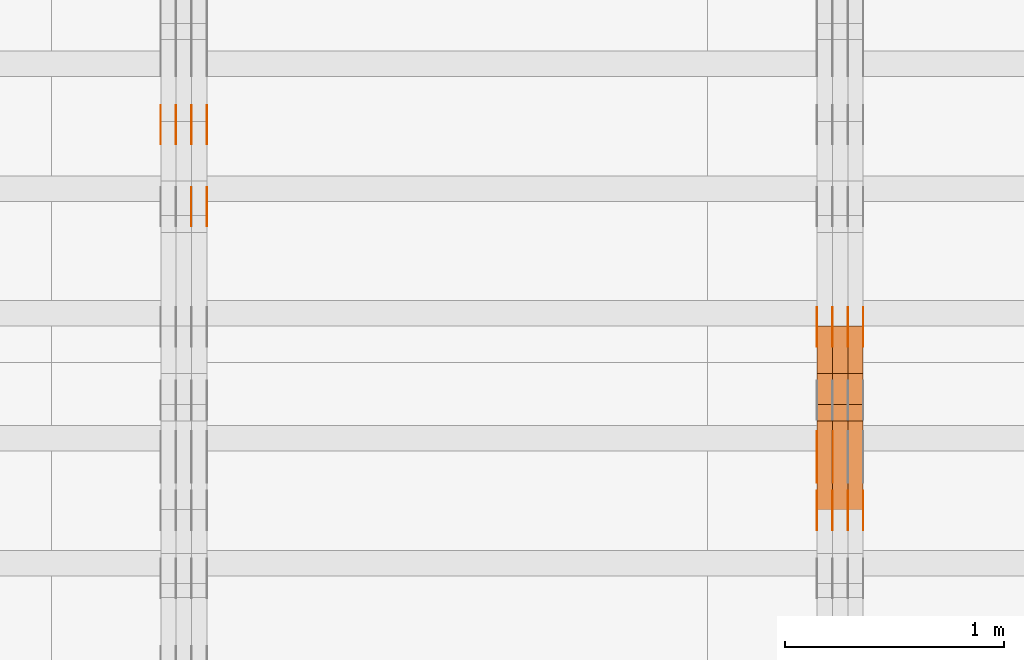
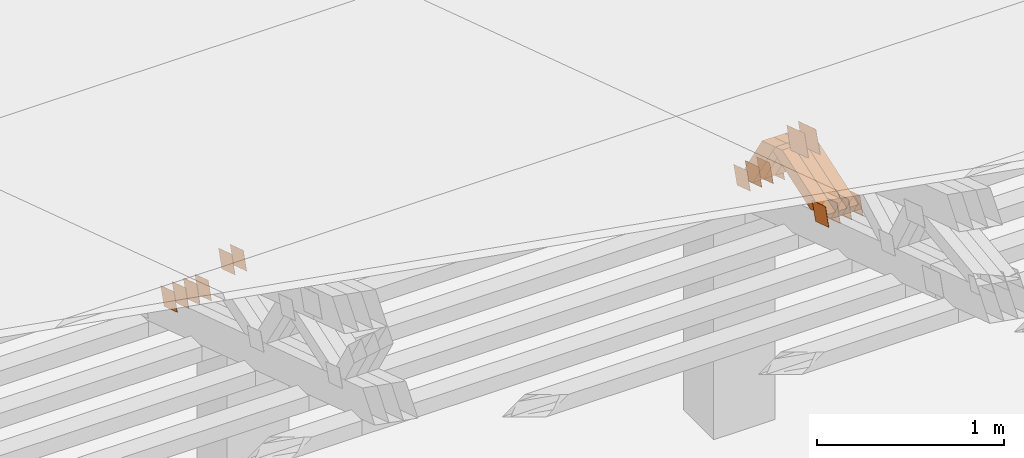
# One storey, part 338 of 385: 28 proxies.
"""IFC2X3 building model written with IfcOpenShell, lengths in millimetres."""

from ifc_helpers import new_model, entity, si_unit, converted_unit, derived_unit, direction, frame, origin, place, context, subcontext, project, spatial, polyline, outline, extrude, source, transform, mapped, material, type_object, type_shapes, element, save


model = new_model("IFC2X3")

# Units and contexts
model_context = context("Model", 3, precision=0.01, world=origin(), true_north=direction((6.12303176911189e-17, 1.0)))
body_context = subcontext(model_context, "Body", "Model", "MODEL_VIEW")
ifc_project = project(units=[si_unit("LENGTHUNIT", "METRE", prefix="MILLI"), si_unit("AREAUNIT", "SQUARE_METRE"), si_unit("VOLUMEUNIT", "CUBIC_METRE"), converted_unit("PLANEANGLEUNIT", "DEGREE", entity("IfcRatioMeasure", 0.0174532925199433), si_unit("PLANEANGLEUNIT", "RADIAN"), dimensions=[0, 0, 0, 0, 0, 0, 0]), si_unit("MASSUNIT", "GRAM", prefix="KILO"), derived_unit("MASSDENSITYUNIT", [(si_unit("MASSUNIT", "GRAM", prefix="KILO"), 1), (si_unit("LENGTHUNIT", "METRE"), -3)]), si_unit("TIMEUNIT", "SECOND"), si_unit("FREQUENCYUNIT", "HERTZ"), si_unit("THERMODYNAMICTEMPERATUREUNIT", "DEGREE_CELSIUS"), derived_unit("THERMALTRANSMITTANCEUNIT", [(si_unit("MASSUNIT", "GRAM", prefix="KILO"), 1), (si_unit("THERMODYNAMICTEMPERATUREUNIT", "KELVIN"), -1), (si_unit("TIMEUNIT", "SECOND"), -3)]), derived_unit("VOLUMETRICFLOWRATEUNIT", [(si_unit("LENGTHUNIT", "METRE"), 3), (si_unit("TIMEUNIT", "SECOND"), -1)]), si_unit("ELECTRICCURRENTUNIT", "AMPERE"), si_unit("ELECTRICVOLTAGEUNIT", "VOLT"), si_unit("POWERUNIT", "WATT"), si_unit("FORCEUNIT", "NEWTON", prefix="KILO"), si_unit("ILLUMINANCEUNIT", "LUX"), si_unit("LUMINOUSFLUXUNIT", "LUMEN"), si_unit("LUMINOUSINTENSITYUNIT", "CANDELA"), derived_unit("USERDEFINED", [(si_unit("MASSUNIT", "GRAM", prefix="KILO"), -1), (si_unit("LENGTHUNIT", "METRE"), -2), (si_unit("TIMEUNIT", "SECOND"), 3), (si_unit("LUMINOUSFLUXUNIT", "LUMEN"), 1)]), derived_unit("LINEARVELOCITYUNIT", [(si_unit("LENGTHUNIT", "METRE"), 1), (si_unit("TIMEUNIT", "SECOND"), -1)]), si_unit("PRESSUREUNIT", "PASCAL"), derived_unit("USERDEFINED", [(si_unit("LENGTHUNIT", "METRE"), -2), (si_unit("MASSUNIT", "GRAM", prefix="KILO"), 1), (si_unit("TIMEUNIT", "SECOND"), -2)])], contexts=[model_context])

# Site, building, storey
site_placement = place(None, origin())
site = spatial("IfcSite", under=ifc_project, at=site_placement, CompositionType="ELEMENT")
building_placement = place(site_placement, origin())
building = spatial("IfcBuilding", under=site, at=building_placement, CompositionType="ELEMENT")
storey_placement = place(building_placement, origin())
storey = spatial("IfcBuildingStorey", under=building, at=storey_placement, Name="Default", CompositionType="ELEMENT", Elevation=0.0)

# Proxies
ifc_material_1 = material(Name="IfcSurfaceStyle #485736")
building_element_proxy_type_1 = type_object("IfcBuildingElementProxyType", PredefinedType="NOTDEFINED", material=ifc_material_1)
shared_shape_1 = source(origin(), body_context, "Body", "SweptSolid", [
    extrude(outline(polyline([(-100.000260677523, -72.0000050220369), (100.000341220114, -72.0000050220369), (99.9997962944585, 72.0000050220369), (-99.9998768370492, 72.0000050220369), (-100.000260677523, -72.0000050220369)])), frame((100.000341220114, 72.0001826453454, 0.0), z_axis=(0.0, 0.0, 1.0), x_axis=(-1.0, 0.0, 0.0)), (0.0, 0.0, 1.0), 1.29999999999998),
])
type_shapes(building_element_proxy_type_1, [shared_shape_1])
proxy_1_placement = place(building_placement, frame((39246.3, 20382.8706354426, 2409.35285895246), z_axis=(-1.0, 0.0, 0.0), x_axis=(0.0, -0.951056516295154, 0.309016994374948)))
element("IfcBuildingElementProxy", 1, at=proxy_1_placement, inside=storey, type_object=building_element_proxy_type_1, material=ifc_material_1, context=body_context, shape_type="MappedRepresentation", body=[
    mapped(shared_shape_1, transform((0.0, 0.0, 0.0), scale=1.0)),
])
ifc_material_2 = material(Name="IfcSurfaceStyle #485679")
building_element_proxy_type_2 = type_object("IfcBuildingElementProxyType", PredefinedType="NOTDEFINED", material=ifc_material_2)
shared_shape_2 = source(origin(), body_context, "Body", "SweptSolid", [
    extrude(outline(polyline([(-100.000260677523, -72.0000050220369), (100.000341220114, -72.0000050220369), (99.9997962944585, 72.0000050220369), (-99.9998768370492, 72.0000050220369), (-100.000260677523, -72.0000050220369)])), frame((100.000341220114, 72.0001826453454, 0.0), z_axis=(0.0, 0.0, 1.0), x_axis=(-1.0, 0.0, 0.0)), (0.0, 0.0, 1.0), 1.29999999999999),
])
type_shapes(building_element_proxy_type_2, [shared_shape_2])
proxy_2_placement = place(building_placement, frame((39175.0, 20382.8706354426, 2409.35285895246), z_axis=(-1.0, 0.0, 0.0), x_axis=(0.0, -0.951056516295154, 0.309016994374948)))
element("IfcBuildingElementProxy", 2, at=proxy_2_placement, inside=storey, type_object=building_element_proxy_type_2, material=ifc_material_2, context=body_context, shape_type="MappedRepresentation", body=[
    mapped(shared_shape_2, transform((0.0, 0.0, 0.0), scale=1.0)),
])
ifc_material_3 = material(Name="IfcSurfaceStyle #479466")
building_element_proxy_type_3 = type_object("IfcBuildingElementProxyType", PredefinedType="NOTDEFINED", material=ifc_material_3)
shared_shape_3 = source(origin(), body_context, "Body", "SweptSolid", [
    extrude(outline(polyline([(-74.9998605591118, -59.9999264677598), (74.9998754286171, -59.9999264677598), (74.9998605591136, 59.9999264677598), (-74.9998754286189, 59.9999264677598), (-74.9998605591118, -59.9999264677598)])), frame((75.0000347664736, 60.0000016373434, 0.0), z_axis=(0.0, 0.0, 1.0), x_axis=(-1.0, 0.0, 0.0)), (0.0, 0.0, 1.0), 1.3),
])
type_shapes(building_element_proxy_type_3, [shared_shape_3])
proxy_3_placement = place(building_placement, frame((39386.3, 20117.0890328685, 2105.40814929196), z_axis=(-1.0, 0.0, 0.0), x_axis=(0.0, -0.951056516295124, 0.309016994375039)))
element("IfcBuildingElementProxy", 3, at=proxy_3_placement, inside=storey, type_object=building_element_proxy_type_3, material=ifc_material_3, context=body_context, shape_type="MappedRepresentation", body=[
    mapped(shared_shape_3, transform((0.0, 0.0, 0.0), scale=1.0)),
])
ifc_material_4 = material(Name="IfcSurfaceStyle #479409")
building_element_proxy_type_4 = type_object("IfcBuildingElementProxyType", PredefinedType="NOTDEFINED", material=ifc_material_4)
shared_shape_4 = source(origin(), body_context, "Body", "SweptSolid", [
    extrude(outline(polyline([(-74.9998605591118, -59.9999264677598), (74.9998754286171, -59.9999264677598), (74.9998605591136, 59.9999264677598), (-74.9998754286189, 59.9999264677598), (-74.9998605591118, -59.9999264677598)])), frame((75.0000347664736, 60.0000016373434, 0.0), z_axis=(0.0, 0.0, 1.0), x_axis=(-1.0, 0.0, 0.0)), (0.0, 0.0, 1.0), 1.3),
])
type_shapes(building_element_proxy_type_4, [shared_shape_4])
proxy_4_placement = place(building_placement, frame((39315.0, 20117.0890328685, 2105.40814929196), z_axis=(-1.0, 0.0, 0.0), x_axis=(0.0, -0.951056516295124, 0.309016994375039)))
element("IfcBuildingElementProxy", 4, at=proxy_4_placement, inside=storey, type_object=building_element_proxy_type_4, material=ifc_material_4, context=body_context, shape_type="MappedRepresentation", body=[
    mapped(shared_shape_4, transform((0.0, 0.0, 0.0), scale=1.0)),
])
ifc_material_5 = material(Name="IfcSurfaceStyle #479352")
building_element_proxy_type_5 = type_object("IfcBuildingElementProxyType", PredefinedType="NOTDEFINED", material=ifc_material_5)
shared_shape_5 = source(origin(), body_context, "Body", "SweptSolid", [
    extrude(outline(polyline([(-74.9998605591118, -59.9999264677598), (74.9998754286171, -59.9999264677598), (74.9998605591136, 59.9999264677598), (-74.9998754286189, 59.9999264677598), (-74.9998605591118, -59.9999264677598)])), frame((75.0000347664736, 60.0000016373434, 0.0), z_axis=(0.0, 0.0, 1.0), x_axis=(-1.0, 0.0, 0.0)), (0.0, 0.0, 1.0), 1.3),
])
type_shapes(building_element_proxy_type_5, [shared_shape_5])
proxy_5_placement = place(building_placement, frame((39316.3, 20117.0890328685, 2105.40814929196), z_axis=(-1.0, 0.0, 0.0), x_axis=(0.0, -0.951056516295124, 0.309016994375039)))
element("IfcBuildingElementProxy", 5, at=proxy_5_placement, inside=storey, type_object=building_element_proxy_type_5, material=ifc_material_5, context=body_context, shape_type="MappedRepresentation", body=[
    mapped(shared_shape_5, transform((0.0, 0.0, 0.0), scale=1.0)),
])
ifc_material_6 = material(Name="IfcSurfaceStyle #479295")
building_element_proxy_type_6 = type_object("IfcBuildingElementProxyType", PredefinedType="NOTDEFINED", material=ifc_material_6)
shared_shape_6 = source(origin(), body_context, "Body", "SweptSolid", [
    extrude(outline(polyline([(-74.9998605591118, -59.9999264677598), (74.9998754286171, -59.9999264677598), (74.9998605591136, 59.9999264677598), (-74.9998754286189, 59.9999264677598), (-74.9998605591118, -59.9999264677598)])), frame((75.0000347664736, 60.0000016373434, 0.0), z_axis=(0.0, 0.0, 1.0), x_axis=(-1.0, 0.0, 0.0)), (0.0, 0.0, 1.0), 1.29999999999999),
])
type_shapes(building_element_proxy_type_6, [shared_shape_6])
proxy_6_placement = place(building_placement, frame((39245.0, 20117.0890328685, 2105.40814929196), z_axis=(-1.0, 0.0, 0.0), x_axis=(0.0, -0.951056516295124, 0.309016994375039)))
element("IfcBuildingElementProxy", 6, at=proxy_6_placement, inside=storey, type_object=building_element_proxy_type_6, material=ifc_material_6, context=body_context, shape_type="MappedRepresentation", body=[
    mapped(shared_shape_6, transform((0.0, 0.0, 0.0), scale=1.0)),
])
ifc_material_7 = material(Name="IfcSurfaceStyle #479238")
building_element_proxy_type_7 = type_object("IfcBuildingElementProxyType", PredefinedType="NOTDEFINED", material=ifc_material_7)
shared_shape_7 = source(origin(), body_context, "Body", "SweptSolid", [
    extrude(outline(polyline([(-74.9998605591118, -59.9999264677598), (74.9998754286171, -59.9999264677598), (74.9998605591136, 59.9999264677598), (-74.9998754286189, 59.9999264677598), (-74.9998605591118, -59.9999264677598)])), frame((75.0000347664736, 60.0000016373434, 0.0), z_axis=(0.0, 0.0, 1.0), x_axis=(-1.0, 0.0, 0.0)), (0.0, 0.0, 1.0), 1.29999999999999),
])
type_shapes(building_element_proxy_type_7, [shared_shape_7])
proxy_7_placement = place(building_placement, frame((39246.3, 20117.0890328685, 2105.40814929196), z_axis=(-1.0, 0.0, 0.0), x_axis=(0.0, -0.951056516295124, 0.309016994375039)))
element("IfcBuildingElementProxy", 7, at=proxy_7_placement, inside=storey, type_object=building_element_proxy_type_7, material=ifc_material_7, context=body_context, shape_type="MappedRepresentation", body=[
    mapped(shared_shape_7, transform((0.0, 0.0, 0.0), scale=1.0)),
])
ifc_material_8 = material(Name="IfcSurfaceStyle #479181")
building_element_proxy_type_8 = type_object("IfcBuildingElementProxyType", PredefinedType="NOTDEFINED", material=ifc_material_8)
shared_shape_8 = source(origin(), body_context, "Body", "SweptSolid", [
    extrude(outline(polyline([(-74.9998605591118, -59.9999264677598), (74.9998754286171, -59.9999264677598), (74.9998605591136, 59.9999264677598), (-74.9998754286189, 59.9999264677598), (-74.9998605591118, -59.9999264677598)])), frame((75.0000347664736, 60.0000016373434, 0.0), z_axis=(0.0, 0.0, 1.0), x_axis=(-1.0, 0.0, 0.0)), (0.0, 0.0, 1.0), 1.29999999999999),
])
type_shapes(building_element_proxy_type_8, [shared_shape_8])
proxy_8_placement = place(building_placement, frame((39175.0, 20117.0890328685, 2105.40814929196), z_axis=(-1.0, 0.0, 0.0), x_axis=(0.0, -0.951056516295124, 0.309016994375039)))
element("IfcBuildingElementProxy", 8, at=proxy_8_placement, inside=storey, type_object=building_element_proxy_type_8, material=ifc_material_8, context=body_context, shape_type="MappedRepresentation", body=[
    mapped(shared_shape_8, transform((0.0, 0.0, 0.0), scale=1.0)),
])
ifc_material_9 = material(Name="IfcSurfaceStyle #479124")
building_element_proxy_type_9 = type_object("IfcBuildingElementProxyType", PredefinedType="NOTDEFINED", material=ifc_material_9)
shared_shape_9 = source(origin(), body_context, "Body", "SweptSolid", [
    extrude(outline(polyline([(-74.9998794200132, -59.999984515643), (74.9998565677174, -59.999984515643), (74.9998794200123, 59.999984515643), (-74.9998565677165, 59.999984515643), (-74.9998794200132, -59.999984515643)])), frame((75.0002235343086, 60.0000596852268, 0.0), z_axis=(0.0, 0.0, 1.0), x_axis=(-1.0, 0.0, 0.0)), (0.0, 0.0, 1.0), 1.3),
])
type_shapes(building_element_proxy_type_9, [shared_shape_9])
proxy_9_placement = place(building_placement, frame((39386.3, 20956.2317725846, 1832.75404405346), z_axis=(-1.0, 0.0, 0.0), x_axis=(0.0, -0.951056516295124, 0.309016994375039)))
element("IfcBuildingElementProxy", 9, at=proxy_9_placement, inside=storey, type_object=building_element_proxy_type_9, material=ifc_material_9, context=body_context, shape_type="MappedRepresentation", body=[
    mapped(shared_shape_9, transform((0.0, 0.0, 0.0), scale=1.0)),
])
ifc_material_10 = material(Name="IfcSurfaceStyle #479067")
building_element_proxy_type_10 = type_object("IfcBuildingElementProxyType", PredefinedType="NOTDEFINED", material=ifc_material_10)
shared_shape_10 = source(origin(), body_context, "Body", "SweptSolid", [
    extrude(outline(polyline([(-74.9998794200132, -59.999984515643), (74.9998565677174, -59.999984515643), (74.9998794200123, 59.999984515643), (-74.9998565677165, 59.999984515643), (-74.9998794200132, -59.999984515643)])), frame((75.0002235343086, 60.0000596852268, 0.0), z_axis=(0.0, 0.0, 1.0), x_axis=(-1.0, 0.0, 0.0)), (0.0, 0.0, 1.0), 1.3),
])
type_shapes(building_element_proxy_type_10, [shared_shape_10])
proxy_10_placement = place(building_placement, frame((39315.0, 20956.2317725846, 1832.75404405346), z_axis=(-1.0, 0.0, 0.0), x_axis=(0.0, -0.951056516295124, 0.309016994375039)))
element("IfcBuildingElementProxy", 10, at=proxy_10_placement, inside=storey, type_object=building_element_proxy_type_10, material=ifc_material_10, context=body_context, shape_type="MappedRepresentation", body=[
    mapped(shared_shape_10, transform((0.0, 0.0, 0.0), scale=1.0)),
])
ifc_material_11 = material(Name="IfcSurfaceStyle #479010")
building_element_proxy_type_11 = type_object("IfcBuildingElementProxyType", PredefinedType="NOTDEFINED", material=ifc_material_11)
shared_shape_11 = source(origin(), body_context, "Body", "SweptSolid", [
    extrude(outline(polyline([(-74.9998794200132, -59.999984515643), (74.9998565677174, -59.999984515643), (74.9998794200123, 59.999984515643), (-74.9998565677165, 59.999984515643), (-74.9998794200132, -59.999984515643)])), frame((75.0002235343086, 60.0000596852268, 0.0), z_axis=(0.0, 0.0, 1.0), x_axis=(-1.0, 0.0, 0.0)), (0.0, 0.0, 1.0), 1.3),
])
type_shapes(building_element_proxy_type_11, [shared_shape_11])
proxy_11_placement = place(building_placement, frame((39316.3, 20956.2317725846, 1832.75404405346), z_axis=(-1.0, 0.0, 0.0), x_axis=(0.0, -0.951056516295124, 0.309016994375039)))
element("IfcBuildingElementProxy", 11, at=proxy_11_placement, inside=storey, type_object=building_element_proxy_type_11, material=ifc_material_11, context=body_context, shape_type="MappedRepresentation", body=[
    mapped(shared_shape_11, transform((0.0, 0.0, 0.0), scale=1.0)),
])
ifc_material_12 = material(Name="IfcSurfaceStyle #478953")
building_element_proxy_type_12 = type_object("IfcBuildingElementProxyType", PredefinedType="NOTDEFINED", material=ifc_material_12)
shared_shape_12 = source(origin(), body_context, "Body", "SweptSolid", [
    extrude(outline(polyline([(-74.9998794200132, -59.999984515643), (74.9998565677174, -59.999984515643), (74.9998794200123, 59.999984515643), (-74.9998565677165, 59.999984515643), (-74.9998794200132, -59.999984515643)])), frame((75.0002235343086, 60.0000596852268, 0.0), z_axis=(0.0, 0.0, 1.0), x_axis=(-1.0, 0.0, 0.0)), (0.0, 0.0, 1.0), 1.29999999999999),
])
type_shapes(building_element_proxy_type_12, [shared_shape_12])
proxy_12_placement = place(building_placement, frame((39245.0, 20956.2317725846, 1832.75404405346), z_axis=(-1.0, 0.0, 0.0), x_axis=(0.0, -0.951056516295124, 0.309016994375039)))
element("IfcBuildingElementProxy", 12, at=proxy_12_placement, inside=storey, type_object=building_element_proxy_type_12, material=ifc_material_12, context=body_context, shape_type="MappedRepresentation", body=[
    mapped(shared_shape_12, transform((0.0, 0.0, 0.0), scale=1.0)),
])
ifc_material_13 = material(Name="IfcSurfaceStyle #478896")
building_element_proxy_type_13 = type_object("IfcBuildingElementProxyType", PredefinedType="NOTDEFINED", material=ifc_material_13)
shared_shape_13 = source(origin(), body_context, "Body", "SweptSolid", [
    extrude(outline(polyline([(-74.9998794200132, -59.999984515643), (74.9998565677174, -59.999984515643), (74.9998794200123, 59.999984515643), (-74.9998565677165, 59.999984515643), (-74.9998794200132, -59.999984515643)])), frame((75.0002235343086, 60.0000596852268, 0.0), z_axis=(0.0, 0.0, 1.0), x_axis=(-1.0, 0.0, 0.0)), (0.0, 0.0, 1.0), 1.29999999999999),
])
type_shapes(building_element_proxy_type_13, [shared_shape_13])
proxy_13_placement = place(building_placement, frame((39246.3, 20956.2317725846, 1832.75404405346), z_axis=(-1.0, 0.0, 0.0), x_axis=(0.0, -0.951056516295124, 0.309016994375039)))
element("IfcBuildingElementProxy", 13, at=proxy_13_placement, inside=storey, type_object=building_element_proxy_type_13, material=ifc_material_13, context=body_context, shape_type="MappedRepresentation", body=[
    mapped(shared_shape_13, transform((0.0, 0.0, 0.0), scale=1.0)),
])
ifc_material_14 = material(Name="IfcSurfaceStyle #478839")
building_element_proxy_type_14 = type_object("IfcBuildingElementProxyType", PredefinedType="NOTDEFINED", material=ifc_material_14)
shared_shape_14 = source(origin(), body_context, "Body", "SweptSolid", [
    extrude(outline(polyline([(-74.9998794200132, -59.999984515643), (74.9998565677174, -59.999984515643), (74.9998794200123, 59.999984515643), (-74.9998565677165, 59.999984515643), (-74.9998794200132, -59.999984515643)])), frame((75.0002235343086, 60.0000596852268, 0.0), z_axis=(0.0, 0.0, 1.0), x_axis=(-1.0, 0.0, 0.0)), (0.0, 0.0, 1.0), 1.29999999999999),
])
type_shapes(building_element_proxy_type_14, [shared_shape_14])
proxy_14_placement = place(building_placement, frame((39175.0, 20956.2317725846, 1832.75404405346), z_axis=(-1.0, 0.0, 0.0), x_axis=(0.0, -0.951056516295124, 0.309016994375039)))
element("IfcBuildingElementProxy", 14, at=proxy_14_placement, inside=storey, type_object=building_element_proxy_type_14, material=ifc_material_14, context=body_context, shape_type="MappedRepresentation", body=[
    mapped(shared_shape_14, transform((0.0, 0.0, 0.0), scale=1.0)),
])
ifc_material_15 = material(Name="IfcSurfaceStyle #461862")
building_element_proxy_type_15 = type_object("IfcBuildingElementProxyType", Name="T1-W26 461860", PredefinedType="NOTDEFINED", material=ifc_material_15)
shared_shape_15 = source(origin(), body_context, "Body", "SweptSolid", [
    extrude(outline(polyline([(-339.390941716546, -47.5001331548025), (137.738864791781, -47.5001331548025), (201.272298560955, 6.02772073885038e-05), (212.703852542003, 47.5001030161988), (-212.324074178193, 47.5001030161988), (-339.390941716546, -47.5001331548025)])), frame((212.703852542003, 47.5001030161988, 0.0), z_axis=(0.0, 0.0, 1.0), x_axis=(-1.0, 0.0, 0.0)), (0.0, 0.0, 1.0), 70.0),
])
type_shapes(building_element_proxy_type_15, [shared_shape_15])
proxy_15_placement = place(building_placement, frame((39385.0, 20576.541015625, 2286.80981445313), z_axis=(-1.0, 0.0, 0.0), x_axis=(0.0, -0.946743816465327, -0.321987804093053)))
element("IfcBuildingElementProxy", 15, at=proxy_15_placement, inside=storey, type_object=building_element_proxy_type_15, material=ifc_material_15, Name="T1-W26", context=body_context, shape_type="MappedRepresentation", body=[
    mapped(shared_shape_15, transform((0.0, 0.0, 0.0), scale=1.0)),
])
ifc_material_16 = material(Name="IfcSurfaceStyle #461796")
building_element_proxy_type_16 = type_object("IfcBuildingElementProxyType", Name="T1-W26 461794", PredefinedType="NOTDEFINED", material=ifc_material_16)
shared_shape_16 = source(origin(), body_context, "Body", "SweptSolid", [
    extrude(outline(polyline([(-339.390941716546, -47.5001331548025), (137.738864791781, -47.5001331548025), (201.272298560955, 6.02772073885038e-05), (212.703852542003, 47.5001030161988), (-212.324074178193, 47.5001030161988), (-339.390941716546, -47.5001331548025)])), frame((212.703852542003, 47.5001030161988, 0.0), z_axis=(0.0, 0.0, 1.0), x_axis=(-1.0, 0.0, 0.0)), (0.0, 0.0, 1.0), 70.0),
])
type_shapes(building_element_proxy_type_16, [shared_shape_16])
proxy_16_placement = place(building_placement, frame((39315.0, 20576.541015625, 2286.80981445313), z_axis=(-1.0, 0.0, 0.0), x_axis=(0.0, -0.946743816465327, -0.321987804093053)))
element("IfcBuildingElementProxy", 16, at=proxy_16_placement, inside=storey, type_object=building_element_proxy_type_16, material=ifc_material_16, Name="T1-W26", context=body_context, shape_type="MappedRepresentation", body=[
    mapped(shared_shape_16, transform((0.0, 0.0, 0.0), scale=1.0)),
])
ifc_material_17 = material(Name="IfcSurfaceStyle #461730")
building_element_proxy_type_17 = type_object("IfcBuildingElementProxyType", Name="T1-W26 461728", PredefinedType="NOTDEFINED", material=ifc_material_17)
shared_shape_17 = source(origin(), body_context, "Body", "SweptSolid", [
    extrude(outline(polyline([(-339.390941716546, -47.5001331548025), (137.738864791781, -47.5001331548025), (201.272298560955, 6.02772073885038e-05), (212.703852542003, 47.5001030161988), (-212.324074178193, 47.5001030161988), (-339.390941716546, -47.5001331548025)])), frame((212.703852542003, 47.5001030161988, 0.0), z_axis=(0.0, 0.0, 1.0), x_axis=(-1.0, 0.0, 0.0)), (0.0, 0.0, 1.0), 70.0),
])
type_shapes(building_element_proxy_type_17, [shared_shape_17])
proxy_17_placement = place(building_placement, frame((39245.0, 20576.541015625, 2286.80981445313), z_axis=(-1.0, 0.0, 0.0), x_axis=(0.0, -0.946743816465327, -0.321987804093053)))
element("IfcBuildingElementProxy", 17, at=proxy_17_placement, inside=storey, type_object=building_element_proxy_type_17, material=ifc_material_17, Name="T1-W26", context=body_context, shape_type="MappedRepresentation", body=[
    mapped(shared_shape_17, transform((0.0, 0.0, 0.0), scale=1.0)),
])
ifc_material_18 = material(Name="IfcSurfaceStyle #461466")
building_element_proxy_type_18 = type_object("IfcBuildingElementProxyType", Name="T1-W29 461464", PredefinedType="NOTDEFINED", material=ifc_material_18)
shared_shape_18 = source(origin(), body_context, "Body", "SweptSolid", [
    extrude(outline(polyline([(-202.325994317059, -47.5000867467013), (200.714255560873, -47.5000867467013), (187.834128885383, 0.000593513395139059), (130.590899902046, 47.4997899900038), (-316.813290031243, 47.4997899900038), (-202.325994317059, -47.5000867467013)])), frame((200.714255560873, 47.5001935424745, 0.0), z_axis=(0.0, 0.0, 1.0), x_axis=(-1.0, 0.0, 0.0)), (0.0, 0.0, 1.0), 70.0),
])
type_shapes(building_element_proxy_type_18, [shared_shape_18])
proxy_18_placement = place(building_placement, frame((39385.0, 20827.0771193222, 1890.72342063252), z_axis=(-1.0, 0.0, 0.0), x_axis=(0.0, -0.534567451138397, 0.845125813227473)))
element("IfcBuildingElementProxy", 18, at=proxy_18_placement, inside=storey, type_object=building_element_proxy_type_18, material=ifc_material_18, Name="T1-W29", context=body_context, shape_type="MappedRepresentation", body=[
    mapped(shared_shape_18, transform((0.0, 0.0, 0.0), scale=1.0)),
])
ifc_material_19 = material(Name="IfcSurfaceStyle #461400")
building_element_proxy_type_19 = type_object("IfcBuildingElementProxyType", Name="T1-W29 461398", PredefinedType="NOTDEFINED", material=ifc_material_19)
shared_shape_19 = source(origin(), body_context, "Body", "SweptSolid", [
    extrude(outline(polyline([(-202.325994317059, -47.5000867467013), (200.714255560873, -47.5000867467013), (187.834128885383, 0.000593513395139059), (130.590899902046, 47.4997899900038), (-316.813290031243, 47.4997899900038), (-202.325994317059, -47.5000867467013)])), frame((200.714255560873, 47.5001935424745, 0.0), z_axis=(0.0, 0.0, 1.0), x_axis=(-1.0, 0.0, 0.0)), (0.0, 0.0, 1.0), 70.0),
])
type_shapes(building_element_proxy_type_19, [shared_shape_19])
proxy_19_placement = place(building_placement, frame((39315.0, 20827.0771193222, 1890.72342063252), z_axis=(-1.0, 0.0, 0.0), x_axis=(0.0, -0.534567451138397, 0.845125813227473)))
element("IfcBuildingElementProxy", 19, at=proxy_19_placement, inside=storey, type_object=building_element_proxy_type_19, material=ifc_material_19, Name="T1-W29", context=body_context, shape_type="MappedRepresentation", body=[
    mapped(shared_shape_19, transform((0.0, 0.0, 0.0), scale=1.0)),
])
ifc_material_20 = material(Name="IfcSurfaceStyle #461334")
building_element_proxy_type_20 = type_object("IfcBuildingElementProxyType", Name="T1-W29 461332", PredefinedType="NOTDEFINED", material=ifc_material_20)
shared_shape_20 = source(origin(), body_context, "Body", "SweptSolid", [
    extrude(outline(polyline([(-202.325994317059, -47.5000867467013), (200.714255560873, -47.5000867467013), (187.834128885383, 0.000593513395139059), (130.590899902046, 47.4997899900038), (-316.813290031243, 47.4997899900038), (-202.325994317059, -47.5000867467013)])), frame((200.714255560873, 47.5001935424745, 0.0), z_axis=(0.0, 0.0, 1.0), x_axis=(-1.0, 0.0, 0.0)), (0.0, 0.0, 1.0), 70.0),
])
type_shapes(building_element_proxy_type_20, [shared_shape_20])
proxy_20_placement = place(building_placement, frame((39245.0, 20827.0771193222, 1890.72342063252), z_axis=(-1.0, 0.0, 0.0), x_axis=(0.0, -0.534567451138397, 0.845125813227473)))
element("IfcBuildingElementProxy", 20, at=proxy_20_placement, inside=storey, type_object=building_element_proxy_type_20, material=ifc_material_20, Name="T1-W29", context=body_context, shape_type="MappedRepresentation", body=[
    mapped(shared_shape_20, transform((0.0, 0.0, 0.0), scale=1.0)),
])
ifc_material_21 = material(Name="IfcSurfaceStyle #444350")
building_element_proxy_type_21 = type_object("IfcBuildingElementProxyType", PredefinedType="NOTDEFINED", material=ifc_material_21)
shared_shape_21 = source(origin(), body_context, "Body", "SweptSolid", [
    extrude(outline(polyline([(-75.0001116115454, -60.0000599592451), (75.0000887592496, -60.0000599592451), (75.0001116115454, 60.0000599592451), (-75.0000887592496, 60.0000599592451), (-75.0001116115454, -60.0000599592451)])), frame((75.0001116115454, 60.0000599592451, 0.0), z_axis=(0.0, 0.0, 1.0), x_axis=(-1.0, 0.0, 0.0)), (0.0, 0.0, 1.0), 1.3),
])
type_shapes(building_element_proxy_type_21, [shared_shape_21])
proxy_21_placement = place(building_placement, frame((36386.3, 21881.0815195707, 1532.2522473242), z_axis=(-1.0, 0.0, 0.0), x_axis=(0.0, -0.951056516295124, 0.309016994375039)))
element("IfcBuildingElementProxy", 21, at=proxy_21_placement, inside=storey, type_object=building_element_proxy_type_21, material=ifc_material_21, context=body_context, shape_type="MappedRepresentation", body=[
    mapped(shared_shape_21, transform((0.0, 0.0, 0.0), scale=1.0)),
])
ifc_material_22 = material(Name="IfcSurfaceStyle #444293")
building_element_proxy_type_22 = type_object("IfcBuildingElementProxyType", PredefinedType="NOTDEFINED", material=ifc_material_22)
shared_shape_22 = source(origin(), body_context, "Body", "SweptSolid", [
    extrude(outline(polyline([(-75.0001116115454, -60.0000599592451), (75.0000887592496, -60.0000599592451), (75.0001116115454, 60.0000599592451), (-75.0000887592496, 60.0000599592451), (-75.0001116115454, -60.0000599592451)])), frame((75.0001116115454, 60.0000599592451, 0.0), z_axis=(0.0, 0.0, 1.0), x_axis=(-1.0, 0.0, 0.0)), (0.0, 0.0, 1.0), 1.3),
])
type_shapes(building_element_proxy_type_22, [shared_shape_22])
proxy_22_placement = place(building_placement, frame((36315.0, 21881.0815195707, 1532.2522473242), z_axis=(-1.0, 0.0, 0.0), x_axis=(0.0, -0.951056516295124, 0.309016994375039)))
element("IfcBuildingElementProxy", 22, at=proxy_22_placement, inside=storey, type_object=building_element_proxy_type_22, material=ifc_material_22, context=body_context, shape_type="MappedRepresentation", body=[
    mapped(shared_shape_22, transform((0.0, 0.0, 0.0), scale=1.0)),
])
ifc_material_23 = material(Name="IfcSurfaceStyle #444236")
building_element_proxy_type_23 = type_object("IfcBuildingElementProxyType", PredefinedType="NOTDEFINED", material=ifc_material_23)
shared_shape_23 = source(origin(), body_context, "Body", "SweptSolid", [
    extrude(outline(polyline([(-75.0001116115454, -60.0000599592451), (75.0000887592496, -60.0000599592451), (75.0001116115454, 60.0000599592451), (-75.0000887592496, 60.0000599592451), (-75.0001116115454, -60.0000599592451)])), frame((75.0001116115454, 60.0000599592451, 0.0), z_axis=(0.0, 0.0, 1.0), x_axis=(-1.0, 0.0, 0.0)), (0.0, 0.0, 1.0), 1.3),
])
type_shapes(building_element_proxy_type_23, [shared_shape_23])
proxy_23_placement = place(building_placement, frame((36316.3, 21881.0815195707, 1532.2522473242), z_axis=(-1.0, 0.0, 0.0), x_axis=(0.0, -0.951056516295124, 0.309016994375039)))
element("IfcBuildingElementProxy", 23, at=proxy_23_placement, inside=storey, type_object=building_element_proxy_type_23, material=ifc_material_23, context=body_context, shape_type="MappedRepresentation", body=[
    mapped(shared_shape_23, transform((0.0, 0.0, 0.0), scale=1.0)),
])
ifc_material_24 = material(Name="IfcSurfaceStyle #444179")
building_element_proxy_type_24 = type_object("IfcBuildingElementProxyType", PredefinedType="NOTDEFINED", material=ifc_material_24)
shared_shape_24 = source(origin(), body_context, "Body", "SweptSolid", [
    extrude(outline(polyline([(-75.0001116115454, -60.0000599592451), (75.0000887592496, -60.0000599592451), (75.0001116115454, 60.0000599592451), (-75.0000887592496, 60.0000599592451), (-75.0001116115454, -60.0000599592451)])), frame((75.0001116115454, 60.0000599592451, 0.0), z_axis=(0.0, 0.0, 1.0), x_axis=(-1.0, 0.0, 0.0)), (0.0, 0.0, 1.0), 1.29999999999999),
])
type_shapes(building_element_proxy_type_24, [shared_shape_24])
proxy_24_placement = place(building_placement, frame((36245.0, 21881.0815195707, 1532.2522473242), z_axis=(-1.0, 0.0, 0.0), x_axis=(0.0, -0.951056516295124, 0.309016994375039)))
element("IfcBuildingElementProxy", 24, at=proxy_24_placement, inside=storey, type_object=building_element_proxy_type_24, material=ifc_material_24, context=body_context, shape_type="MappedRepresentation", body=[
    mapped(shared_shape_24, transform((0.0, 0.0, 0.0), scale=1.0)),
])
ifc_material_25 = material(Name="IfcSurfaceStyle #444122")
building_element_proxy_type_25 = type_object("IfcBuildingElementProxyType", PredefinedType="NOTDEFINED", material=ifc_material_25)
shared_shape_25 = source(origin(), body_context, "Body", "SweptSolid", [
    extrude(outline(polyline([(-75.0001116115454, -60.0000599592451), (75.0000887592496, -60.0000599592451), (75.0001116115454, 60.0000599592451), (-75.0000887592496, 60.0000599592451), (-75.0001116115454, -60.0000599592451)])), frame((75.0001116115454, 60.0000599592451, 0.0), z_axis=(0.0, 0.0, 1.0), x_axis=(-1.0, 0.0, 0.0)), (0.0, 0.0, 1.0), 1.29999999999999),
])
type_shapes(building_element_proxy_type_25, [shared_shape_25])
proxy_25_placement = place(building_placement, frame((36246.3, 21881.0815195707, 1532.2522473242), z_axis=(-1.0, 0.0, 0.0), x_axis=(0.0, -0.951056516295124, 0.309016994375039)))
element("IfcBuildingElementProxy", 25, at=proxy_25_placement, inside=storey, type_object=building_element_proxy_type_25, material=ifc_material_25, context=body_context, shape_type="MappedRepresentation", body=[
    mapped(shared_shape_25, transform((0.0, 0.0, 0.0), scale=1.0)),
])
ifc_material_26 = material(Name="IfcSurfaceStyle #444065")
building_element_proxy_type_26 = type_object("IfcBuildingElementProxyType", PredefinedType="NOTDEFINED", material=ifc_material_26)
shared_shape_26 = source(origin(), body_context, "Body", "SweptSolid", [
    extrude(outline(polyline([(-75.0001116115454, -60.0000599592451), (75.0000887592496, -60.0000599592451), (75.0001116115454, 60.0000599592451), (-75.0000887592496, 60.0000599592451), (-75.0001116115454, -60.0000599592451)])), frame((75.0001116115454, 60.0000599592451, 0.0), z_axis=(0.0, 0.0, 1.0), x_axis=(-1.0, 0.0, 0.0)), (0.0, 0.0, 1.0), 1.29999999999999),
])
type_shapes(building_element_proxy_type_26, [shared_shape_26])
proxy_26_placement = place(building_placement, frame((36175.0, 21881.0815195707, 1532.2522473242), z_axis=(-1.0, 0.0, 0.0), x_axis=(0.0, -0.951056516295124, 0.309016994375039)))
element("IfcBuildingElementProxy", 26, at=proxy_26_placement, inside=storey, type_object=building_element_proxy_type_26, material=ifc_material_26, context=body_context, shape_type="MappedRepresentation", body=[
    mapped(shared_shape_26, transform((0.0, 0.0, 0.0), scale=1.0)),
])
ifc_material_27 = material(Name="IfcSurfaceStyle #438878")
building_element_proxy_type_27 = type_object("IfcBuildingElementProxyType", PredefinedType="NOTDEFINED", material=ifc_material_27)
shared_shape_27 = source(origin(), body_context, "Body", "SweptSolid", [
    extrude(outline(polyline([(-74.9998794200064, -59.9999845156358), (74.9998565677224, -59.9999845156358), (74.9998794200064, 59.9999845156358), (-74.9998565677224, 59.9999845156358), (-74.9998794200064, -59.9999845156358)])), frame((74.9999765995044, 60.0000596852337, 0.0), z_axis=(0.0, 0.0, 1.0), x_axis=(-1.0, 0.0, 0.0)), (0.0, 0.0, 1.0), 1.3),
])
type_shapes(building_element_proxy_type_27, [shared_shape_27])
proxy_27_placement = place(building_placement, frame((36386.3, 21505.9776314857, 1954.5332951652), z_axis=(-1.0, 0.0, 0.0), x_axis=(0.0, -0.951056516295154, 0.309016994374948)))
element("IfcBuildingElementProxy", 27, at=proxy_27_placement, inside=storey, type_object=building_element_proxy_type_27, material=ifc_material_27, context=body_context, shape_type="MappedRepresentation", body=[
    mapped(shared_shape_27, transform((0.0, 0.0, 0.0), scale=1.0)),
])
ifc_material_28 = material(Name="IfcSurfaceStyle #438821")
building_element_proxy_type_28 = type_object("IfcBuildingElementProxyType", PredefinedType="NOTDEFINED", material=ifc_material_28)
shared_shape_28 = source(origin(), body_context, "Body", "SweptSolid", [
    extrude(outline(polyline([(-74.9998794200064, -59.9999845156358), (74.9998565677224, -59.9999845156358), (74.9998794200064, 59.9999845156358), (-74.9998565677224, 59.9999845156358), (-74.9998794200064, -59.9999845156358)])), frame((74.9999765995044, 60.0000596852337, 0.0), z_axis=(0.0, 0.0, 1.0), x_axis=(-1.0, 0.0, 0.0)), (0.0, 0.0, 1.0), 1.3),
])
type_shapes(building_element_proxy_type_28, [shared_shape_28])
proxy_28_placement = place(building_placement, frame((36315.0, 21505.9776314857, 1954.5332951652), z_axis=(-1.0, 0.0, 0.0), x_axis=(0.0, -0.951056516295154, 0.309016994374948)))
element("IfcBuildingElementProxy", 28, at=proxy_28_placement, inside=storey, type_object=building_element_proxy_type_28, material=ifc_material_28, context=body_context, shape_type="MappedRepresentation", body=[
    mapped(shared_shape_28, transform((0.0, 0.0, 0.0), scale=1.0)),
])

save(model, "model.ifc")
